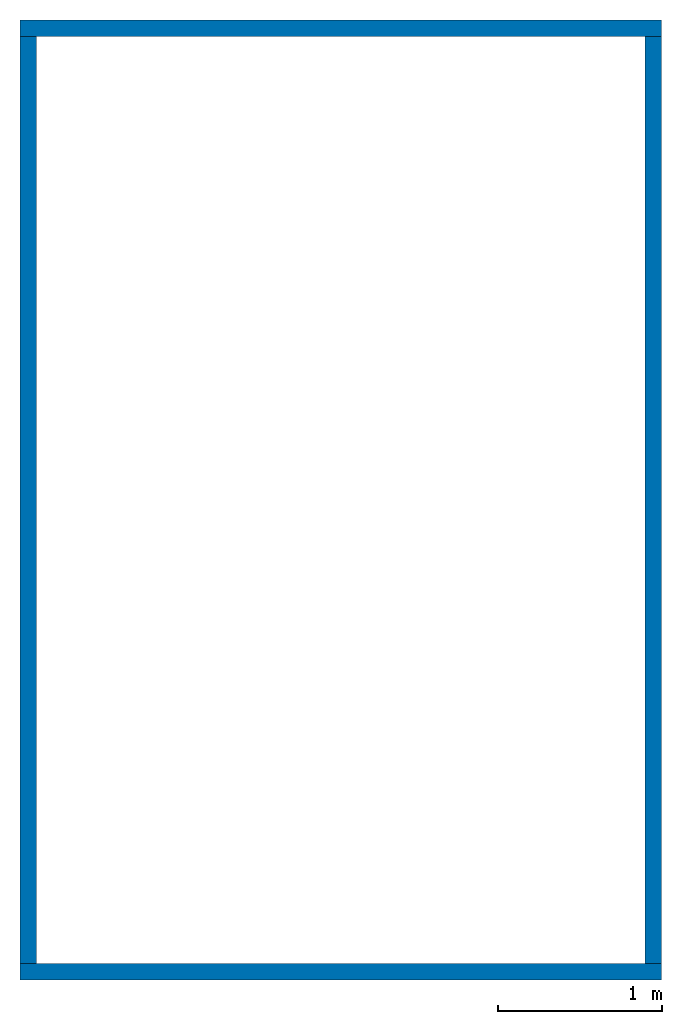
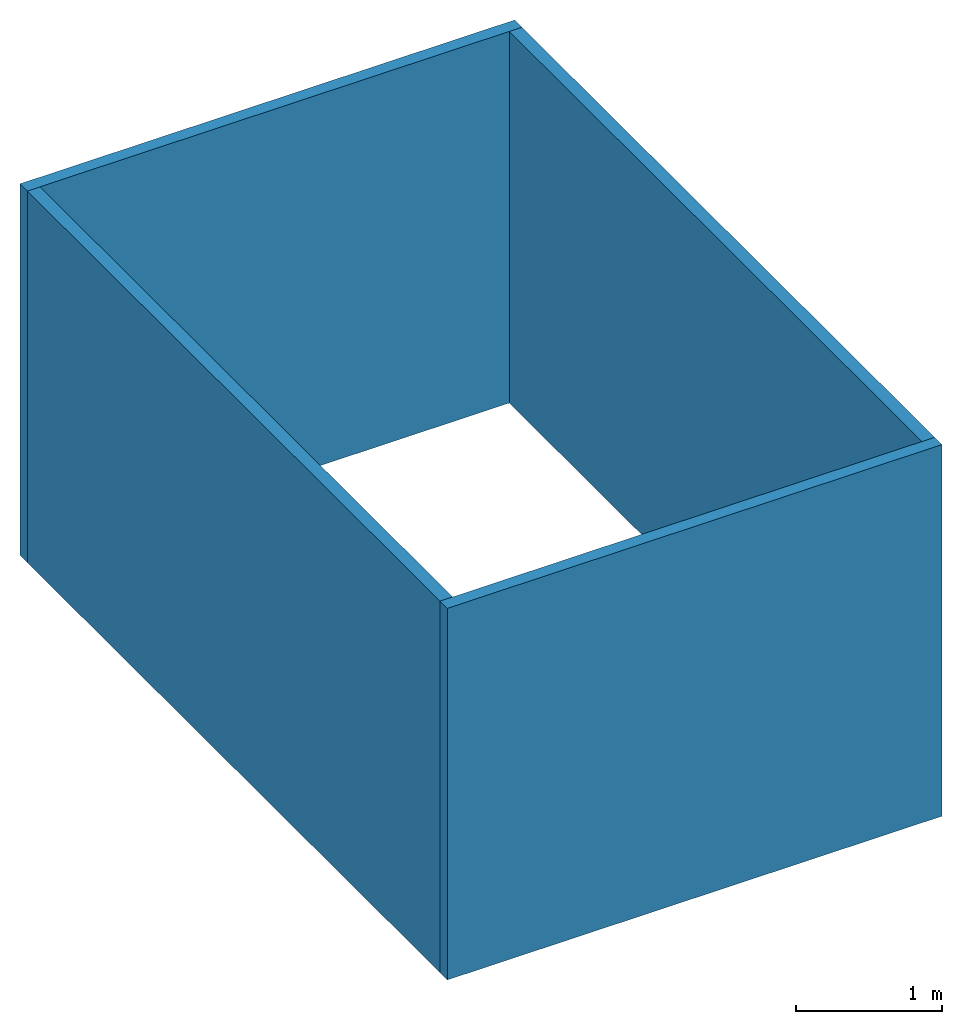
# Not in any storey: 4 walls, 1 element without a shape of its own.
"""IFC4 model written with IfcOpenShell, lengths in metres."""

from ifc_helpers import new_model, entity, si_unit, converted_unit, frame, origin_with_axes, origin_2d_with_axis, place, context, subcontext, project, indexed_curve, outline, extrude, clip, halfspace, material, layer, layer_set, layer_usage, type_object, element, aggregate, save


model = new_model("IFC4")

# Units and contexts
model_context = context("Model", 3, precision=1e-05, world=origin_with_axes())
plan_context = context("Plan", 2, precision=1e-05, world=origin_2d_with_axis())
body_context = subcontext(model_context, "Body", "Model", "MODEL_VIEW")
ifc_project = project(units=[si_unit("VOLUMEUNIT", "CUBIC_METRE"), si_unit("LENGTHUNIT", "METRE"), converted_unit("PLANEANGLEUNIT", "degree", entity("IfcReal", 0.0174532925199433), si_unit("PLANEANGLEUNIT", "RADIAN"), dimensions=[0, 0, 0, 0, 0, 0, 0]), si_unit("AREAUNIT", "SQUARE_METRE")], contexts=[model_context, plan_context])

# Assembly, walls
placement_1 = place(None, origin_with_axes())
placement_2 = place(placement_1, origin_with_axes())
placement_3 = place(placement_2, origin_with_axes())
assembly_placement = place(placement_3, origin_with_axes())
assembly = element("IfcElementAssembly", 1, at=assembly_placement)
ifc_material = material()
ifc_layer = layer(ifc_material, 0.1)
ifc_layer_set = layer_set([ifc_layer])
ifc_layer_usage_1 = layer_usage(ifc_layer_set, "AXIS2", "POSITIVE", 0.0)
wall_type = type_object("IfcWallType", Name="wall", PredefinedType="SOLIDWALL", material=ifc_layer_set)
wall_1_placement = place(assembly_placement, frame((1.71551732819353e-06, 5.74088954925537, 0.0), z_axis=(0.0, 0.0, 1.0), x_axis=(-2.82129974493717e-07, -0.99999999999996, 0.0)))
wall_1 = element("IfcWall", 2, at=wall_1_placement, type_object=wall_type, material=ifc_layer_usage_1, Name="Wall", context=body_context, shape_type="Clipping", body=[
    clip(extrude(outline(indexed_curve([(0.0, 0.0), (0.0, 0.1), (5.6408890849929, 0.1), (5.6408890849929, 0.0), (0.0, 0.0)], self_intersect=False)), origin_with_axes(), (0.0, 0.0, 1.0), 3.1000000984438), halfspace(frame((-4.84057238736568e-13, 0.0, 3.10000014305115), z_axis=(0.0, 0.0, 1.0), x_axis=(-1.0, 0.0, 0.0)), False)),
])
ifc_layer_usage_2 = layer_usage(ifc_layer_set, "AXIS2", "POSITIVE", 0.0)
wall_2_placement = place(assembly_placement, origin_with_axes())
wall_2 = element("IfcWall", 3, at=wall_2_placement, type_object=wall_type, material=ifc_layer_usage_2, Name="Wall", context=body_context, shape_type="Clipping", body=[
    clip(extrude(outline(indexed_curve([(0.0, 0.0), (0.0, 0.1), (3.90270334597408, 0.1), (3.90270334597408, 0.0), (0.0, 0.0)], self_intersect=False)), origin_with_axes(), (0.0, 0.0, 1.0), 3.1000000984438), halfspace(frame((0.0, 0.0, 3.10000014305115), z_axis=(0.0, 0.0, 1.0), x_axis=(-1.0, 0.0, 0.0)), False)),
])
ifc_layer_usage_3 = layer_usage(ifc_layer_set, "AXIS2", "POSITIVE", 0.0)
wall_3_placement = place(assembly_placement, frame((3.80270481109619, 5.74088954925537, 0.0), z_axis=(0.0, 0.0, 1.0), x_axis=(-2.82129974493717e-07, -0.99999999999996, 0.0)))
wall_3 = element("IfcWall", 4, at=wall_3_placement, type_object=wall_type, material=ifc_layer_usage_3, Name="Wall", context=body_context, shape_type="Clipping", body=[
    clip(extrude(outline(indexed_curve([(0.0, 0.0), (0.0, 0.1), (5.64088908499292, 0.1), (5.64088908499292, 0.0), (0.0, 0.0)], self_intersect=False)), origin_with_axes(), (0.0, 0.0, 1.0), 3.1000000984438), halfspace(frame((-1.19182686830754e-07, 4.92530034534866e-08, 3.10000014305115), z_axis=(0.0, 0.0, 1.0), x_axis=(-1.0, 0.0, 0.0)), False)),
])
ifc_layer_usage_4 = layer_usage(ifc_layer_set, "AXIS2", "POSITIVE", 0.0)
wall_4_placement = place(assembly_placement, frame((0.0, 5.74088954925537, 0.0), z_axis=(0.0, 0.0, 1.0), x_axis=(1.0, 0.0, 0.0)))
wall_4 = element("IfcWall", 5, at=wall_4_placement, type_object=wall_type, material=ifc_layer_usage_4, Name="Wall", context=body_context, shape_type="Clipping", body=[
    clip(extrude(outline(indexed_curve([(0.0, 0.0), (0.0, 0.1), (3.90270334597408, 0.1), (3.90270334597408, 0.0), (0.0, 0.0)], self_intersect=False)), origin_with_axes(), (0.0, 0.0, 1.0), 3.1000000984438), halfspace(frame((0.0, 0.0, 3.10000014305115), z_axis=(0.0, 0.0, 1.0), x_axis=(-1.0, 0.0, 0.0)), False)),
])
aggregate(assembly, [wall_1, wall_2, wall_3, wall_4])

save(model, "model.ifc")
